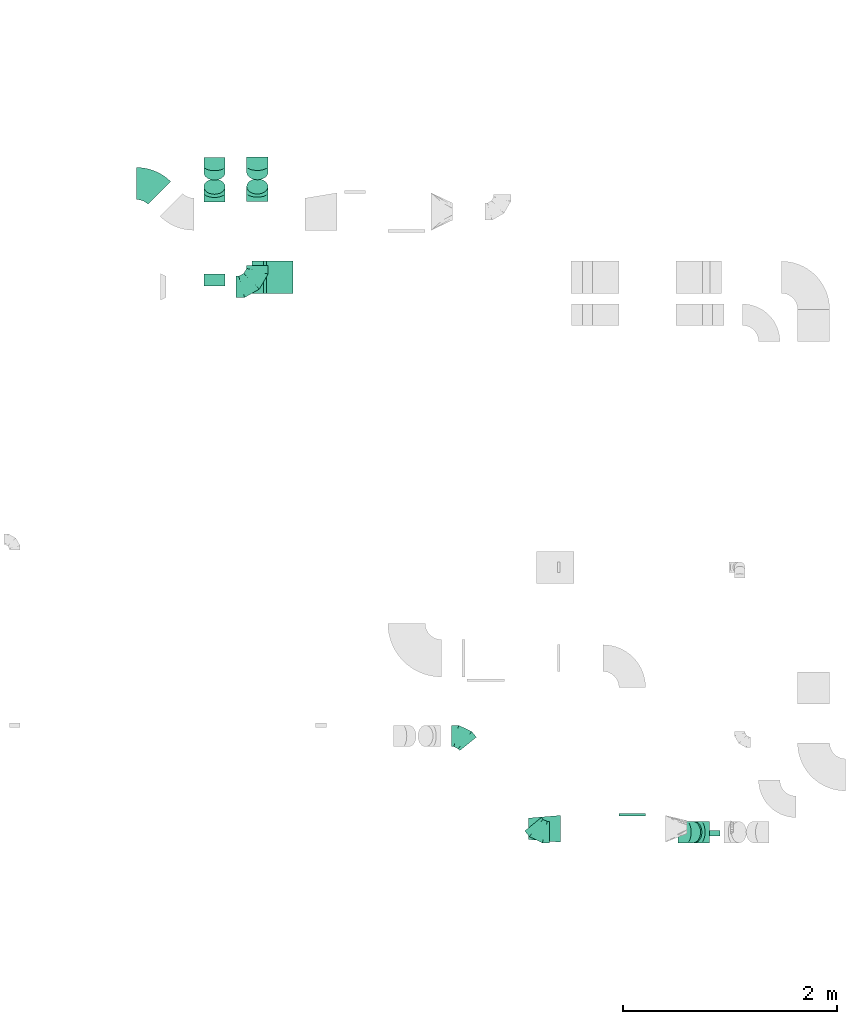
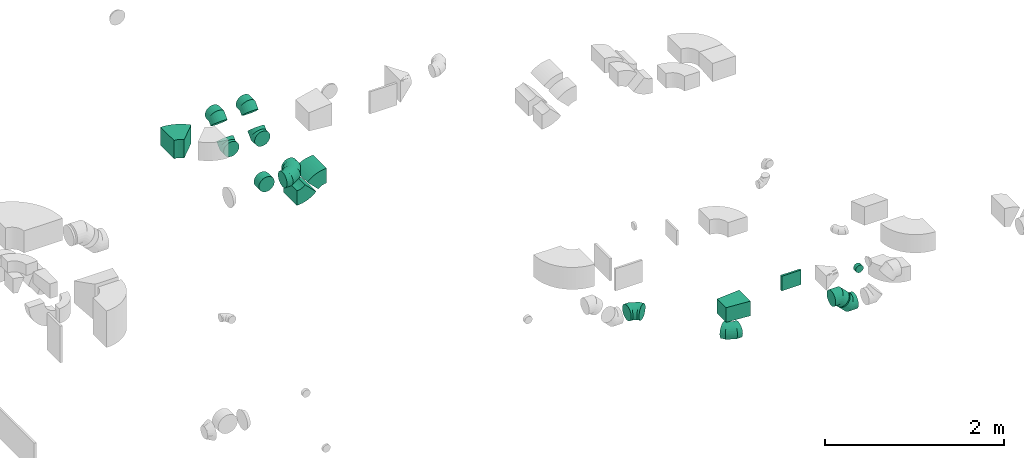
# One storey, part 28 of 44: 16 flow fittings.
"""IFC2X3 building model written with IfcOpenShell, lengths in millimetres."""

from ifc_helpers import new_model, entity, si_unit, converted_unit, derived_unit, direction, frame, frame_2d, origin, origin_2d_with_axis, place, context, subcontext, project, spatial, polyline, circle_curve, parameter, trimmed, segment, composite_curve, rectangle, outline, extrude, faceted_brep, source, transform, mapped, material, type_object, type_shapes, element, save


model = new_model("IFC2X3")

# Units and contexts
model_context = context("Model", 3, precision=0.01, world=origin(), true_north=direction((6.12303176911189e-17, 1.0)))
body_context = subcontext(model_context, "Body", "Model", "MODEL_VIEW")
ifc_project = project(units=[si_unit("LENGTHUNIT", "METRE", prefix="MILLI"), si_unit("AREAUNIT", "SQUARE_METRE"), si_unit("VOLUMEUNIT", "CUBIC_METRE"), converted_unit("PLANEANGLEUNIT", "DEGREE", entity("IfcRatioMeasure", 0.0174532925199433), si_unit("PLANEANGLEUNIT", "RADIAN"), dimensions=[0, 0, 0, 0, 0, 0, 0]), si_unit("MASSUNIT", "GRAM", prefix="KILO"), derived_unit("MASSDENSITYUNIT", [(si_unit("MASSUNIT", "GRAM", prefix="KILO"), 1), (si_unit("LENGTHUNIT", "METRE"), -3)]), derived_unit("MOMENTOFINERTIAUNIT", [(si_unit("LENGTHUNIT", "METRE"), 4)]), si_unit("TIMEUNIT", "SECOND"), si_unit("FREQUENCYUNIT", "HERTZ"), si_unit("THERMODYNAMICTEMPERATUREUNIT", "DEGREE_CELSIUS"), derived_unit("THERMALTRANSMITTANCEUNIT", [(si_unit("MASSUNIT", "GRAM", prefix="KILO"), 1), (si_unit("THERMODYNAMICTEMPERATUREUNIT", "KELVIN"), -1), (si_unit("TIMEUNIT", "SECOND"), -3)]), derived_unit("VOLUMETRICFLOWRATEUNIT", [(si_unit("LENGTHUNIT", "METRE"), 3), (si_unit("TIMEUNIT", "SECOND"), -1)]), derived_unit("MASSFLOWRATEUNIT", [(si_unit("MASSUNIT", "GRAM", prefix="KILO"), 1), (si_unit("TIMEUNIT", "SECOND"), -1)]), derived_unit("ROTATIONALFREQUENCYUNIT", [(si_unit("TIMEUNIT", "SECOND"), -1)]), si_unit("ELECTRICCURRENTUNIT", "AMPERE"), si_unit("ELECTRICVOLTAGEUNIT", "VOLT"), si_unit("POWERUNIT", "WATT"), si_unit("FORCEUNIT", "NEWTON", prefix="KILO"), si_unit("ILLUMINANCEUNIT", "LUX"), si_unit("LUMINOUSFLUXUNIT", "LUMEN"), si_unit("LUMINOUSINTENSITYUNIT", "CANDELA"), derived_unit("USERDEFINED", [(si_unit("MASSUNIT", "GRAM", prefix="KILO"), -1), (si_unit("LENGTHUNIT", "METRE"), -2), (si_unit("TIMEUNIT", "SECOND"), 3), (si_unit("LUMINOUSFLUXUNIT", "LUMEN"), 1)]), derived_unit("LINEARVELOCITYUNIT", [(si_unit("LENGTHUNIT", "METRE"), 1), (si_unit("TIMEUNIT", "SECOND"), -1)]), si_unit("PRESSUREUNIT", "PASCAL"), derived_unit("USERDEFINED", [(si_unit("LENGTHUNIT", "METRE"), -2), (si_unit("MASSUNIT", "GRAM", prefix="KILO"), 1), (si_unit("TIMEUNIT", "SECOND"), -2)]), derived_unit("LINEARFORCEUNIT", [(si_unit("MASSUNIT", "GRAM", prefix="KILO"), 1), (si_unit("LENGTHUNIT", "METRE"), 1), (si_unit("TIMEUNIT", "SECOND"), -2), (si_unit("LENGTHUNIT", "METRE"), -1)]), derived_unit("PLANARFORCEUNIT", [(si_unit("MASSUNIT", "GRAM", prefix="KILO"), 1), (si_unit("LENGTHUNIT", "METRE"), 1), (si_unit("TIMEUNIT", "SECOND"), -2), (si_unit("LENGTHUNIT", "METRE"), -2)])], contexts=[model_context])

# Site, building, storey
site_placement = place(None, origin())
site = spatial("IfcSite", under=ifc_project, at=site_placement, CompositionType="ELEMENT")
building_placement = place(site_placement, origin())
building = spatial("IfcBuilding", under=site, at=building_placement, CompositionType="ELEMENT")
storey_placement = place(building_placement, frame((0.0, 0.0, 15900.0)))
storey = spatial("IfcBuildingStorey", under=building, at=storey_placement, CompositionType="ELEMENT", Elevation=15900.0)

# Flow fittings
ifc_material = material()
duct_fitting_type_1 = type_object("IfcDuctFittingType", PredefinedType="NOTDEFINED", material=ifc_material)
shared_shape_1 = source(origin(), body_context, "Body", "SweptSolid", [
    extrude(rectangle(XDim=250.0, YDim=26.0960000000122, at=origin_2d_with_axis()), frame((6.95, 0.0, -100.0), z_axis=(0.0, 0.0, 1.0), x_axis=(0.0, -1.0, 0.0)), (0.0, 0.0, 1.0), 200.0),
])
type_shapes(duct_fitting_type_1, [shared_shape_1])
flow_fitting_1_placement = place(storey_placement, frame((60349.84, 9495.12, 3375.0), z_axis=(0.0, 0.0, -1.0), x_axis=(0.0, 1.0, 0.0)))
element("IfcFlowFitting", 1, at=flow_fitting_1_placement, inside=storey, type_object=duct_fitting_type_1, material=ifc_material, context=body_context, shape_type="MappedRepresentation", body=[
    mapped(shared_shape_1, transform((0.0, 0.0, 0.0), scale=1.0)),
])
duct_fitting_type_2 = type_object("IfcDuctFittingType", PredefinedType="NOTDEFINED", material=ifc_material)
shared_shape_2 = source(origin(), body_context, "Body", "SweptSolid", [
    extrude(outline(polyline([(-141.18, -112.11), (159.86, -112.11), (139.1, 137.03), (-157.79, 87.2), (-141.18, -112.11)])), frame((150.0, 0.0, -100.0), z_axis=(0.0, 0.0, 1.0), x_axis=(0.996545758244879, -0.0830454798537418, 0.0)), (0.0, 0.0, 1.0), 200.0),
])
type_shapes(duct_fitting_type_2, [shared_shape_2])
flow_fitting_2_placement = place(storey_placement, frame((59379.84, 9370.12, 3375.0)))
element("IfcFlowFitting", 2, at=flow_fitting_2_placement, inside=storey, type_object=duct_fitting_type_2, material=ifc_material, context=body_context, shape_type="MappedRepresentation", body=[
    mapped(shared_shape_2, transform((0.0, 0.0, 0.0), scale=1.0)),
])
duct_fitting_type_3 = type_object("IfcDuctFittingType", PredefinedType="NOTDEFINED", material=ifc_material)
shared_shape_3 = source(origin(), body_context, "Body", "Brep", [
    faceted_brep([(-200.0, 0.0, -100.0), (-200.0, -25.88, -96.59), (-200.0, -50.0, -86.6), (-200.0, -70.71, -70.71), (-200.0, -86.6, -50.0), (-200.0, -96.59, -25.88), (-200.0, -100.0, 0.0), (-200.0, -96.59, 25.88), (-200.0, -86.6, 50.0), (-200.0, -70.71, 70.71), (-200.0, -50.0, 86.6), (-200.0, -25.88, 96.59), (-200.0, 0.0, 100.0), (-200.0, 25.88, 96.59), (-200.0, 50.0, 86.6), (-200.0, 70.71, 70.71), (-200.0, 86.6, 50.0), (-200.0, 96.59, 25.88), (-200.0, 100.0, 0.0), (-200.0, 96.59, -25.88), (-200.0, 86.6, -50.0), (-200.0, 70.71, -70.71), (-200.0, 50.0, -86.6), (-200.0, 25.88, -96.59), (-153.35, 25.88, 96.59), (-159.81, 50.0, 86.6), (-146.41, 0.0, 100.0), (-165.36, 70.71, 70.71), (-172.29, 96.59, 25.88), (-173.21, 100.0, 0.0), (-169.62, 86.6, 50.0), (-169.62, 86.6, -50.0), (-165.36, 70.71, -70.71), (-172.29, 96.59, -25.88), (-153.35, 25.88, -96.59), (-146.41, 0.0, -100.0), (-159.81, 50.0, -86.6), (-139.48, -25.88, -96.59), (-133.01, -50.0, -86.6), (-127.46, -70.71, -70.71), (-123.21, -86.6, -50.0), (-120.53, -96.59, -25.88), (-119.62, -100.0, 0.0), (-120.53, -96.59, 25.88), (-123.21, -86.6, 50.0), (-127.46, -70.71, 70.71), (-133.01, -50.0, 86.6), (-139.48, -25.88, 96.59), (-72.54, 72.54, 96.59), (-90.19, 90.19, 86.6), (-53.59, 53.59, 100.0), (-105.35, 105.35, 70.71), (-116.99, 116.99, 50.0), (-124.3, 124.3, 25.88), (-126.79, 126.79, 0.0), (-124.3, 124.3, -25.88), (-116.99, 116.99, -50.0), (-105.35, 105.35, -70.71), (-72.54, 72.54, -96.59), (-53.59, 53.59, -100.0), (-90.19, 90.19, -86.6), (-34.64, 34.64, -96.59), (-16.99, 16.99, -86.6), (-1.83, 1.83, -70.71), (9.81, -9.81, -50.0), (17.12, -17.12, -25.88), (19.62, -19.62, 0.0), (17.12, -17.12, 25.88), (9.81, -9.81, 50.0), (-1.83, 1.83, 70.71), (-16.99, 16.99, 86.6), (-34.64, 34.64, 96.59), (-25.88, 153.35, 96.59), (-50.0, 159.81, 86.6), (0.0, 146.41, 100.0), (-70.71, 165.36, 70.71), (-86.6, 169.62, 50.0), (-96.59, 172.29, 25.88), (-100.0, 173.21, 0.0), (-96.59, 172.29, -25.88), (-86.6, 169.62, -50.0), (-70.71, 165.36, -70.71), (-25.88, 153.35, -96.59), (0.0, 146.41, -100.0), (-50.0, 159.81, -86.6), (25.88, 139.48, -96.59), (50.0, 133.01, -86.6), (70.71, 127.46, -70.71), (86.6, 123.21, -50.0), (96.59, 120.53, -25.88), (100.0, 119.62, 0.0), (96.59, 120.53, 25.88), (86.6, 123.21, 50.0), (70.71, 127.46, 70.71), (50.0, 133.01, 86.6), (25.88, 139.48, 96.59), (-25.88, 200.0, -96.59), (-50.0, 200.0, -86.6), (-70.71, 200.0, -70.71), (-86.6, 200.0, -50.0), (-96.59, 200.0, -25.88), (-100.0, 200.0, 0.0), (-96.59, 200.0, 25.88), (-86.6, 200.0, 50.0), (-70.71, 200.0, 70.71), (-50.0, 200.0, 86.6), (-25.88, 200.0, 96.59), (0.0, 200.0, 100.0), (25.88, 200.0, 96.59), (50.0, 200.0, 86.6), (70.71, 200.0, 70.71), (86.6, 200.0, 50.0), (96.59, 200.0, 25.88), (100.0, 200.0, 0.0), (96.59, 200.0, -25.88), (86.6, 200.0, -50.0), (70.71, 200.0, -70.71), (50.0, 200.0, -86.6), (25.88, 200.0, -96.59), (0.0, 200.0, -100.0)], [[[0, 1, 2, 3, 4, 5, 6, 7, 8, 9, 10, 11, 12, 13, 14, 15, 16, 17, 18, 19, 20, 21, 22, 23]], [[24, 25, 14, 13]], [[26, 24, 13, 12]], [[14, 25, 27, 15]], [[28, 29, 18, 17]], [[30, 28, 17, 16]], [[15, 27, 30, 16]], [[20, 31, 32, 21]], [[33, 31, 20, 19]], [[18, 29, 33, 19]], [[34, 35, 0, 23]], [[36, 34, 23, 22]], [[32, 36, 22, 21]], [[1, 0, 35, 37]], [[2, 1, 37, 38]], [[38, 39, 3, 2]], [[5, 4, 40, 41]], [[6, 5, 41, 42]], [[39, 40, 4, 3]], [[6, 42, 43, 7]], [[7, 43, 44, 8]], [[8, 44, 45, 9]], [[9, 45, 46, 10]], [[10, 46, 47, 11]], [[26, 12, 11, 47]], [[48, 49, 25, 24]], [[50, 48, 24, 26]], [[27, 25, 49, 51]], [[52, 53, 28, 30]], [[51, 52, 30, 27]], [[29, 28, 53, 54]], [[55, 56, 31, 33]], [[54, 55, 33, 29]], [[32, 31, 56, 57]], [[58, 59, 35, 34]], [[60, 58, 34, 36]], [[57, 60, 36, 32]], [[37, 35, 59, 61]], [[38, 37, 61, 62]], [[39, 38, 62, 63]], [[41, 40, 64, 65]], [[42, 41, 65, 66]], [[63, 64, 40, 39]], [[43, 42, 66, 67]], [[44, 43, 67, 68]], [[68, 69, 45, 44]], [[46, 45, 69, 70]], [[47, 46, 70, 71]], [[26, 47, 71, 50]], [[72, 73, 49, 48]], [[74, 72, 48, 50]], [[51, 49, 73, 75]], [[76, 77, 53, 52]], [[75, 76, 52, 51]], [[54, 53, 77, 78]], [[79, 80, 56, 55]], [[78, 79, 55, 54]], [[57, 56, 80, 81]], [[82, 83, 59, 58]], [[84, 82, 58, 60]], [[81, 84, 60, 57]], [[61, 59, 83, 85]], [[62, 61, 85, 86]], [[63, 62, 86, 87]], [[65, 64, 88, 89]], [[66, 65, 89, 90]], [[87, 88, 64, 63]], [[67, 66, 90, 91]], [[68, 67, 91, 92]], [[92, 93, 69, 68]], [[70, 69, 93, 94]], [[71, 70, 94, 95]], [[50, 71, 95, 74]], [[96, 97, 98, 99, 100, 101, 102, 103, 104, 105, 106, 107, 108, 109, 110, 111, 112, 113, 114, 115, 116, 117, 118, 119]], [[72, 74, 107, 106]], [[73, 72, 106, 105]], [[75, 73, 105, 104]], [[102, 101, 78, 77]], [[103, 102, 77, 76]], [[75, 104, 103, 76]], [[78, 101, 100, 79]], [[79, 100, 99, 80]], [[80, 99, 98, 81]], [[84, 97, 96, 82]], [[82, 96, 119, 83]], [[84, 81, 98, 97]], [[118, 117, 86, 85]], [[119, 118, 85, 83]], [[116, 87, 86, 117]], [[88, 115, 114, 89]], [[89, 114, 113, 90]], [[115, 88, 87, 116]], [[91, 90, 113, 112]], [[92, 91, 112, 111]], [[111, 110, 93, 92]], [[95, 94, 109, 108]], [[74, 95, 108, 107]], [[110, 109, 94, 93]]]),
])
type_shapes(duct_fitting_type_3, [shared_shape_3])
flow_fitting_3_placement = place(storey_placement, frame((56845.04, 14435.52, 3050.0)))
element("IfcFlowFitting", 3, at=flow_fitting_3_placement, inside=storey, type_object=duct_fitting_type_3, material=ifc_material, context=body_context, shape_type="MappedRepresentation", body=[
    mapped(shared_shape_3, transform((0.0, 0.0, 0.0), scale=1.0)),
])
duct_fitting_type_4 = type_object("IfcDuctFittingType", PredefinedType="NOTDEFINED", material=ifc_material)
shared_shape_4 = source(origin(), body_context, "Body", "Brep", [
    faceted_brep([(-82.84, 0.0, -100.0), (-82.84, -25.88, -96.59), (-82.84, -50.0, -86.6), (-82.84, -70.71, -70.71), (-82.84, -86.6, -50.0), (-82.84, -96.59, -25.88), (-82.84, -100.0, 0.0), (-82.84, -96.59, 25.88), (-82.84, -86.6, 50.0), (-82.84, -70.71, 70.71), (-82.84, -50.0, 86.6), (-82.84, -25.88, 96.59), (-82.84, 0.0, 100.0), (-82.84, 25.88, 96.59), (-82.84, 50.0, 86.6), (-82.84, 70.71, 70.71), (-82.84, 86.6, 50.0), (-82.84, 96.59, 25.88), (-82.84, 100.0, 0.0), (-82.84, 96.59, -25.88), (-82.84, 86.6, -50.0), (-82.84, 70.71, -70.71), (-82.84, 50.0, -86.6), (-82.84, 25.88, -96.59), (-10.72, 25.88, 96.59), (-20.71, 50.0, 86.6), (0.0, 0.0, 100.0), (-29.29, 70.71, 70.71), (-35.87, 86.6, 50.0), (-40.01, 96.59, 25.88), (-41.42, 100.0, 0.0), (-40.01, 96.59, -25.88), (-35.87, 86.6, -50.0), (-29.29, 70.71, -70.71), (-10.72, 25.88, -96.59), (0.0, 0.0, -100.0), (-20.71, 50.0, -86.6), (10.72, -25.88, -96.59), (20.71, -50.0, -86.6), (29.29, -70.71, -70.71), (35.87, -86.6, -50.0), (40.01, -96.59, -25.88), (41.42, -100.0, 0.0), (40.01, -96.59, 25.88), (35.87, -86.6, 50.0), (29.29, -70.71, 70.71), (20.71, -50.0, 86.6), (10.72, -25.88, 96.59), (58.58, 58.58, 100.0), (40.28, 76.88, 96.59), (23.22, 93.93, 86.6), (8.58, 108.58, 70.71), (-2.66, 119.82, 50.0), (-9.72, 126.88, 25.88), (-12.13, 129.29, 0.0), (-9.72, 126.88, -25.88), (-2.66, 119.82, -50.0), (8.58, 108.58, -70.71), (23.22, 93.93, -86.6), (40.28, 76.88, -96.59), (58.58, 58.58, -100.0), (76.88, 40.28, -96.59), (93.93, 23.22, -86.6), (108.58, 8.58, -70.71), (119.82, -2.66, -50.0), (126.88, -9.72, -25.88), (129.29, -12.13, 0.0), (126.88, -9.72, 25.88), (119.82, -2.66, 50.0), (108.58, 8.58, 70.71), (93.93, 23.22, 86.6), (76.88, 40.28, 96.59)], [[[0, 1, 2, 3, 4, 5, 6, 7, 8, 9, 10, 11, 12, 13, 14, 15, 16, 17, 18, 19, 20, 21, 22, 23]], [[24, 25, 14, 13]], [[26, 24, 13, 12]], [[14, 25, 27, 15]], [[28, 29, 17, 16]], [[28, 16, 15, 27]], [[30, 18, 17, 29]], [[31, 32, 20, 19]], [[30, 31, 19, 18]], [[32, 33, 21, 20]], [[34, 35, 0, 23]], [[36, 34, 23, 22]], [[33, 36, 22, 21]], [[1, 0, 35, 37]], [[2, 1, 37, 38]], [[38, 39, 3, 2]], [[5, 4, 40, 41]], [[6, 5, 41, 42]], [[39, 40, 4, 3]], [[6, 42, 43, 7]], [[7, 43, 44, 8]], [[8, 44, 45, 9]], [[9, 45, 46, 10]], [[10, 46, 47, 11]], [[26, 12, 11, 47]], [[24, 26, 48, 49]], [[25, 24, 49, 50]], [[27, 25, 50, 51]], [[29, 28, 52, 53]], [[30, 29, 53, 54]], [[51, 52, 28, 27]], [[30, 54, 55, 31]], [[31, 55, 56, 32]], [[57, 33, 32, 56]], [[36, 58, 59, 34]], [[34, 59, 60, 35]], [[58, 36, 33, 57]], [[35, 60, 61, 37]], [[37, 61, 62, 38]], [[63, 39, 38, 62]], [[40, 64, 65, 41]], [[41, 65, 66, 42]], [[64, 40, 39, 63]], [[43, 42, 66, 67]], [[44, 43, 67, 68]], [[68, 69, 45, 44]], [[47, 46, 70, 71]], [[26, 47, 71, 48]], [[69, 70, 46, 45]], [[59, 58, 57, 56, 55, 54, 53, 52, 51, 50, 49, 48, 71, 70, 69, 68, 67, 66, 65, 64, 63, 62, 61, 60]]]),
])
type_shapes(duct_fitting_type_4, [shared_shape_4])
for number, where, z_axis, x_axis in (
    (4, (56444.3, 15563.36, 3300.0), (1.0, 0.0, 0.0), (0.0, -1.0, 0.0)),
    (5, (56444.3, 15313.36, 3050.0), (-1.0, 0.0, 0.0), (0.0, -0.707106781186484, -0.707106781186611)),
    (6, (56845.04, 15565.52, 3300.0), (1.0, 0.0, 0.0), (0.0, -1.0, 0.0)),
    (7, (56845.04, 15315.52, 3050.0), (-1.0, 0.0, 0.0), (0.0, -0.707106781186484, -0.707106781186611)),
    (8, (60988.67, 9338.57, 2945.0), (0.0, 1.0, 0.0), (-1.0, 0.0, 0.0)),
    (9, (60858.85, 9338.57, 3074.82), (0.0, -1.0, 0.0), (-0.707106781186468, 0.0, 0.707106781186627)),
):
    element("IfcFlowFitting", number, at=place(storey_placement, frame(where, z_axis=z_axis, x_axis=x_axis)), inside=storey, type_object=duct_fitting_type_4, material=ifc_material, context=body_context, shape_type="MappedRepresentation", body=[
        mapped(shared_shape_4, transform((0.0, 0.0, 0.0), scale=1.0)),
    ])
duct_fitting_type_5 = type_object("IfcDuctFittingType", PredefinedType="NOTDEFINED", material=ifc_material)
shared_shape_5 = source(origin(), body_context, "Body", "Brep", [
    faceted_brep([(20.0, 12.94, -48.3), (20.0, 25.0, -43.3), (20.0, 35.36, -35.36), (20.0, 43.3, -25.0), (20.0, 48.3, -12.94), (20.0, 50.0, 0.0), (20.0, 48.3, 12.94), (20.0, 43.3, 25.0), (20.0, 35.36, 35.36), (20.0, 25.0, 43.3), (20.0, 12.94, 48.3), (20.0, 0.0, 50.0), (20.0, -12.94, 48.3), (20.0, -25.0, 43.3), (20.0, -35.36, 35.36), (20.0, -43.3, 25.0), (20.0, -48.3, 12.94), (20.0, -50.0, 0.0), (20.0, -48.3, -12.94), (20.0, -43.3, -25.0), (20.0, -35.36, -35.36), (20.0, -25.0, -43.3), (20.0, -12.94, -48.3), (20.0, 0.0, -50.0), (0.0, 0.0, 50.0), (0.0, 12.94, 48.3), (-31.1, 12.94, 48.3), (-31.1, 0.0, 50.0), (0.0, 25.0, 43.3), (-31.1, 25.0, 43.3), (0.0, 35.36, 35.36), (-31.1, 35.36, 35.36), (0.0, 43.3, 25.0), (0.0, 48.3, 12.94), (-31.1, 48.3, 12.94), (-31.1, 43.3, 25.0), (0.0, 50.0, 0.0), (-31.1, 50.0, 0.0), (0.0, 48.3, -12.94), (-31.1, 48.3, -12.94), (0.0, 43.3, -25.0), (-31.1, 43.3, -25.0), (0.0, 35.36, -35.36), (-31.1, 35.36, -35.36), (0.0, 25.0, -43.3), (0.0, 12.94, -48.3), (-31.1, 12.94, -48.3), (-31.1, 25.0, -43.3), (0.0, 0.0, -50.0), (-31.1, 0.0, -50.0), (0.0, -12.94, -48.3), (-31.1, -12.94, -48.3), (0.0, -25.0, -43.3), (-31.1, -25.0, -43.3), (0.0, -35.36, -35.36), (-31.1, -35.36, -35.36), (0.0, -43.3, -25.0), (0.0, -48.3, -12.94), (-31.1, -48.3, -12.94), (-31.1, -43.3, -25.0), (0.0, -50.0, 0.0), (-31.1, -50.0, 0.0), (0.0, -48.3, 12.94), (-31.1, -48.3, 12.94), (0.0, -43.3, 25.0), (-31.1, -43.3, 25.0), (0.0, -35.36, 35.36), (-31.1, -35.36, 35.36), (0.0, -25.0, 43.3), (0.0, -12.94, 48.3), (-31.1, -12.94, 48.3), (-31.1, -25.0, 43.3)], [[[0, 1, 2, 3, 4, 5, 6, 7, 8, 9, 10, 11, 12, 13, 14, 15, 16, 17, 18, 19, 20, 21, 22, 23]], [[24, 11, 10, 25, 26, 27]], [[25, 10, 9, 28, 29, 26]], [[28, 9, 8, 30, 31, 29]], [[32, 7, 6, 33, 34, 35]], [[33, 6, 5, 36, 37, 34]], [[30, 8, 7, 32, 35, 31]], [[36, 5, 4, 38, 39, 37]], [[38, 4, 3, 40, 41, 39]], [[40, 3, 2, 42, 43, 41]], [[44, 1, 0, 45, 46, 47]], [[45, 0, 23, 48, 49, 46]], [[42, 2, 1, 44, 47, 43]], [[48, 23, 22, 50, 51, 49]], [[50, 22, 21, 52, 53, 51]], [[52, 21, 20, 54, 55, 53]], [[56, 19, 18, 57, 58, 59]], [[57, 18, 17, 60, 61, 58]], [[54, 20, 19, 56, 59, 55]], [[60, 17, 16, 62, 63, 61]], [[62, 16, 15, 64, 65, 63]], [[64, 15, 14, 66, 67, 65]], [[68, 13, 12, 69, 70, 71]], [[69, 12, 11, 24, 27, 70]], [[66, 14, 13, 68, 71, 67]], [[49, 51, 53, 55, 59, 58, 61, 63, 65, 67, 71, 70, 27, 26, 29, 31, 35, 34, 37, 39, 41, 43, 47, 46]]]),
])
type_shapes(duct_fitting_type_5, [shared_shape_5])
flow_fitting_4_placement = place(storey_placement, frame((61120.03, 9322.62, 3375.0), z_axis=(0.0, 0.0, -1.0), x_axis=(0.0, -1.0, 0.0)))
element("IfcFlowFitting", 10, at=flow_fitting_4_placement, inside=storey, type_object=duct_fitting_type_5, material=ifc_material, context=body_context, shape_type="MappedRepresentation", body=[
    mapped(shared_shape_5, transform((0.0, 0.0, 0.0), scale=1.0)),
])
duct_fitting_type_6 = type_object("IfcDuctFittingType", PredefinedType="NOTDEFINED", material=ifc_material)
shared_shape_6 = source(origin(), body_context, "Body", "Brep", [
    faceted_brep([(20.0, 25.88, -96.59), (20.0, 50.0, -86.6), (20.0, 70.71, -70.71), (20.0, 86.6, -50.0), (20.0, 96.59, -25.88), (20.0, 100.0, 0.0), (20.0, 96.59, 25.88), (20.0, 86.6, 50.0), (20.0, 70.71, 70.71), (20.0, 50.0, 86.6), (20.0, 25.88, 96.59), (20.0, 0.0, 100.0), (20.0, -25.88, 96.59), (20.0, -50.0, 86.6), (20.0, -70.71, 70.71), (20.0, -86.6, 50.0), (20.0, -96.59, 25.88), (20.0, -100.0, 0.0), (20.0, -96.59, -25.88), (20.0, -86.6, -50.0), (20.0, -70.71, -70.71), (20.0, -50.0, -86.6), (20.0, -25.88, -96.59), (20.0, 0.0, -100.0), (0.0, 0.0, 100.0), (0.0, 25.88, 96.59), (-93.9, 25.88, 96.59), (-93.9, 0.0, 100.0), (0.0, 50.0, 86.6), (-93.9, 50.0, 86.6), (0.0, 70.71, 70.71), (-93.9, 70.71, 70.71), (0.0, 86.6, 50.0), (0.0, 96.59, 25.88), (-93.9, 96.59, 25.88), (-93.9, 86.6, 50.0), (0.0, 100.0, 0.0), (-93.9, 100.0, 0.0), (0.0, 96.59, -25.88), (-93.9, 96.59, -25.88), (0.0, 86.6, -50.0), (-93.9, 86.6, -50.0), (0.0, 70.71, -70.71), (-93.9, 70.71, -70.71), (0.0, 50.0, -86.6), (0.0, 25.88, -96.59), (-93.9, 25.88, -96.59), (-93.9, 50.0, -86.6), (0.0, 0.0, -100.0), (-93.9, 0.0, -100.0), (0.0, -25.88, -96.59), (-93.9, -25.88, -96.59), (0.0, -50.0, -86.6), (-93.9, -50.0, -86.6), (0.0, -70.71, -70.71), (-93.9, -70.71, -70.71), (0.0, -86.6, -50.0), (0.0, -96.59, -25.88), (-93.9, -96.59, -25.88), (-93.9, -86.6, -50.0), (0.0, -100.0, 0.0), (-93.9, -100.0, 0.0), (0.0, -96.59, 25.88), (-93.9, -96.59, 25.88), (0.0, -86.6, 50.0), (-93.9, -86.6, 50.0), (0.0, -70.71, 70.71), (-93.9, -70.71, 70.71), (0.0, -50.0, 86.6), (0.0, -25.88, 96.59), (-93.9, -25.88, 96.59), (-93.9, -50.0, 86.6)], [[[0, 1, 2, 3, 4, 5, 6, 7, 8, 9, 10, 11, 12, 13, 14, 15, 16, 17, 18, 19, 20, 21, 22, 23]], [[24, 11, 10, 25, 26, 27]], [[25, 10, 9, 28, 29, 26]], [[28, 9, 8, 30, 31, 29]], [[32, 7, 6, 33, 34, 35]], [[33, 6, 5, 36, 37, 34]], [[30, 8, 7, 32, 35, 31]], [[36, 5, 4, 38, 39, 37]], [[38, 4, 3, 40, 41, 39]], [[40, 3, 2, 42, 43, 41]], [[44, 1, 0, 45, 46, 47]], [[45, 0, 23, 48, 49, 46]], [[42, 2, 1, 44, 47, 43]], [[48, 23, 22, 50, 51, 49]], [[50, 22, 21, 52, 53, 51]], [[52, 21, 20, 54, 55, 53]], [[56, 19, 18, 57, 58, 59]], [[57, 18, 17, 60, 61, 58]], [[54, 20, 19, 56, 59, 55]], [[60, 17, 16, 62, 63, 61]], [[62, 16, 15, 64, 65, 63]], [[64, 15, 14, 66, 67, 65]], [[68, 13, 12, 69, 70, 71]], [[69, 12, 11, 24, 27, 70]], [[66, 14, 13, 68, 71, 67]], [[49, 51, 53, 55, 59, 58, 61, 63, 65, 67, 71, 70, 27, 26, 29, 31, 35, 34, 37, 39, 41, 43, 47, 46]]]),
])
type_shapes(duct_fitting_type_6, [shared_shape_6])
flow_fitting_5_placement = place(storey_placement, frame((56444.3, 14535.52, 3050.0), z_axis=(0.0, 0.0, -1.0), x_axis=(0.0, 1.0, 0.0)))
element("IfcFlowFitting", 11, at=flow_fitting_5_placement, inside=storey, type_object=duct_fitting_type_6, material=ifc_material, context=body_context, shape_type="MappedRepresentation", body=[
    mapped(shared_shape_6, transform((0.0, 0.0, 0.0), scale=1.0)),
])
duct_fitting_type_7 = type_object("IfcDuctFittingType", PredefinedType="NOTDEFINED", material=ifc_material)
shared_shape_7 = source(origin(), body_context, "Body", "Brep", [
    faceted_brep([(-95.4, 0.0, -100.0), (-95.4, -25.88, -96.59), (-95.4, -50.0, -86.6), (-95.4, -70.71, -70.71), (-95.4, -86.6, -50.0), (-95.4, -96.59, -25.88), (-95.4, -100.0, 0.0), (-95.4, -96.59, 25.88), (-95.4, -86.6, 50.0), (-95.4, -70.71, 70.71), (-95.4, -50.0, 86.6), (-95.4, -25.88, 96.59), (-95.4, 0.0, 100.0), (-95.4, 25.88, 96.59), (-95.4, 50.0, 86.6), (-95.4, 70.71, 70.71), (-95.4, 86.6, 50.0), (-95.4, 96.59, 25.88), (-95.4, 100.0, 0.0), (-95.4, 96.59, -25.88), (-95.4, 86.6, -50.0), (-95.4, 70.71, -70.71), (-95.4, 50.0, -86.6), (-95.4, 25.88, -96.59), (-56.0, 25.88, 96.59), (-61.45, 50.0, 86.6), (-50.14, 0.0, 100.0), (-66.14, 70.71, 70.71), (-72.0, 96.59, 25.88), (-72.77, 100.0, 0.0), (-69.74, 86.6, 50.0), (-69.74, 86.6, -50.0), (-66.14, 70.71, -70.71), (-72.0, 96.59, -25.88), (-56.0, 25.88, -96.59), (-50.14, 0.0, -100.0), (-61.45, 50.0, -86.6), (-44.28, -25.88, -96.59), (-38.83, -50.0, -86.6), (-34.14, -70.71, -70.71), (-30.54, -86.6, -50.0), (-28.28, -96.59, -25.88), (-27.51, -100.0, 0.0), (-28.28, -96.59, 25.88), (-30.54, -86.6, 50.0), (-34.14, -70.71, 70.71), (-38.83, -50.0, 86.6), (-44.28, -25.88, 96.59), (15.13, 59.81, 96.59), (-0.18, 79.22, 86.6), (31.55, 38.97, 100.0), (-13.33, 95.9, 70.71), (-23.42, 108.7, 50.0), (-29.76, 116.74, 25.88), (-31.92, 119.48, 0.0), (-29.76, 116.74, -25.88), (-23.42, 108.7, -50.0), (-13.33, 95.9, -70.71), (15.13, 59.81, -96.59), (31.55, 38.97, -100.0), (-0.18, 79.22, -86.6), (47.98, 18.13, -96.59), (63.29, -1.29, -86.6), (76.44, -17.97, -70.71), (86.52, -30.76, -50.0), (92.87, -38.81, -25.88), (95.03, -41.55, 0.0), (92.87, -38.81, 25.88), (86.52, -30.76, 50.0), (76.44, -17.97, 70.71), (63.29, -1.29, 86.6), (47.98, 18.13, 96.59), (60.03, 74.14, 100.0), (39.92, 90.42, 96.59), (21.18, 105.6, 86.6), (5.08, 118.64, 70.71), (-7.27, 128.64, 50.0), (-15.03, 134.92, 25.88), (-17.68, 137.07, 0.0), (-15.03, 134.92, -25.88), (-7.27, 128.64, -50.0), (5.08, 118.64, -70.71), (21.18, 105.6, -86.6), (39.92, 90.42, -96.59), (60.03, 74.14, -100.0), (80.15, 57.85, -96.59), (98.89, 42.67, -86.6), (114.99, 29.64, -70.71), (127.34, 19.64, -50.0), (135.1, 13.35, -25.88), (137.75, 11.2, 0.0), (135.1, 13.35, 25.88), (127.34, 19.64, 50.0), (114.99, 29.64, 70.71), (98.89, 42.67, 86.6), (80.15, 57.85, 96.59)], [[[0, 1, 2, 3, 4, 5, 6, 7, 8, 9, 10, 11, 12, 13, 14, 15, 16, 17, 18, 19, 20, 21, 22, 23]], [[24, 25, 14, 13]], [[26, 24, 13, 12]], [[14, 25, 27, 15]], [[28, 29, 18, 17]], [[30, 28, 17, 16]], [[15, 27, 30, 16]], [[20, 31, 32, 21]], [[33, 31, 20, 19]], [[18, 29, 33, 19]], [[34, 35, 0, 23]], [[36, 34, 23, 22]], [[32, 36, 22, 21]], [[1, 0, 35, 37]], [[2, 1, 37, 38]], [[3, 2, 38, 39]], [[5, 4, 40, 41]], [[6, 5, 41, 42]], [[39, 40, 4, 3]], [[6, 42, 43, 7]], [[7, 43, 44, 8]], [[45, 9, 8, 44]], [[9, 45, 46, 10]], [[10, 46, 47, 11]], [[26, 12, 11, 47]], [[48, 49, 25, 24]], [[50, 48, 24, 26]], [[27, 25, 49, 51]], [[52, 53, 28, 30]], [[51, 52, 30, 27]], [[29, 28, 53, 54]], [[55, 56, 31, 33]], [[54, 55, 33, 29]], [[32, 31, 56, 57]], [[58, 59, 35, 34]], [[60, 58, 34, 36]], [[57, 60, 36, 32]], [[37, 35, 59, 61]], [[38, 37, 61, 62]], [[39, 38, 62, 63]], [[41, 40, 64, 65]], [[42, 41, 65, 66]], [[63, 64, 40, 39]], [[43, 42, 66, 67]], [[44, 43, 67, 68]], [[68, 69, 45, 44]], [[46, 45, 69, 70]], [[47, 46, 70, 71]], [[26, 47, 71, 50]], [[48, 50, 72, 73]], [[49, 48, 73, 74]], [[51, 49, 74, 75]], [[53, 52, 76, 77]], [[54, 53, 77, 78]], [[51, 75, 76, 52]], [[54, 78, 79, 55]], [[55, 79, 80, 56]], [[56, 80, 81, 57]], [[60, 82, 83, 58]], [[58, 83, 84, 59]], [[60, 57, 81, 82]], [[59, 84, 85, 61]], [[61, 85, 86, 62]], [[87, 63, 62, 86]], [[64, 88, 89, 65]], [[65, 89, 90, 66]], [[88, 64, 63, 87]], [[91, 92, 68, 67]], [[90, 91, 67, 66]], [[92, 93, 69, 68]], [[71, 70, 94, 95]], [[50, 71, 95, 72]], [[93, 94, 70, 69]], [[83, 82, 81, 80, 79, 78, 77, 76, 75, 74, 73, 72, 95, 94, 93, 92, 91, 90, 89, 88, 87, 86, 85, 84]]]),
])
type_shapes(duct_fitting_type_7, [shared_shape_7])
for number, where, z_axis, x_axis in (
    (12, (59482.27, 9338.57, 3074.82), (0.0, 0.0, 1.0), (0.629320391049837, -0.777145961456972, 0.0)),
    (13, (58754.42, 10237.4, 3074.82), (0.0, 0.0, 1.0), (-0.629320391049822, 0.777145961456983, 0.0)),
):
    element("IfcFlowFitting", number, at=place(storey_placement, frame(where, z_axis=z_axis, x_axis=x_axis)), inside=storey, type_object=duct_fitting_type_7, material=ifc_material, context=body_context, shape_type="MappedRepresentation", body=[
        mapped(shared_shape_7, transform((0.0, 0.0, 0.0), scale=1.0)),
    ])
duct_fitting_type_8 = type_object("IfcDuctFittingType", PredefinedType="NOTDEFINED", material=ifc_material)
shared_shape_8 = source(origin(), body_context, "Body", "SweptSolid", [
    extrude(outline(composite_curve([segment(polyline([(-136.61, -88.39), (63.39, -88.39)]), True, "CONTINUOUS"), segment(trimmed(circle_curve(frame_2d((213.39, -88.39), x_axis=(-0.707106781186546, 0.707106781186546)), 150.0), [parameter(0.0)], [parameter(45.0)], True, "PARAMETER"), False, "CONTINUOUS"), segment(polyline([(107.32, 17.68), (-34.1, 159.1)]), True, "CONTINUOUS"), segment(trimmed(circle_curve(frame_2d((213.39, -88.39), x_axis=(-0.707106781186546, 0.707106781186546)), 350.0), [parameter(0.0)], [parameter(45.0)], True, "PARAMETER"), True, "CONTINUOUS")], self_intersect=False)), frame((-15.17, 36.61, -150.0), z_axis=(0.0, 0.0, 1.0), x_axis=(-0.707106781186547, 0.707106781186548, 0.0)), (0.0, 0.0, 1.0), 300.0),
])
type_shapes(duct_fitting_type_8, [shared_shape_8])
for number, where, z_axis, x_axis in (
    (14, (56899.93, 14525.32, 2777.01), (0.0, -1.0, 0.0), (1.0, 0.0, 0.0)),
    (15, (57072.92, 14525.32, 2950.0), (0.0, 1.0, 0.0), (0.707106781186346, 0.0, 0.70710678118675)),
):
    element("IfcFlowFitting", number, at=place(storey_placement, frame(where, z_axis=z_axis, x_axis=x_axis)), inside=storey, type_object=duct_fitting_type_8, material=ifc_material, context=body_context, shape_type="MappedRepresentation", body=[
        mapped(shared_shape_8, transform((0.0, 0.0, 0.0), scale=1.0)),
    ])
duct_fitting_type_9 = type_object("IfcDuctFittingType", PredefinedType="NOTDEFINED", material=ifc_material)
shared_shape_9 = source(origin(), body_context, "Body", "SweptSolid", [
    extrude(outline(composite_curve([segment(polyline([(-193.93, -106.07), (106.07, -106.07)]), True, "CONTINUOUS"), segment(trimmed(circle_curve(frame_2d((256.07, -106.07), x_axis=(-0.707106781186553, 0.707106781186553)), 150.0), [parameter(0.0)], [parameter(45.0)], True, "PARAMETER"), False, "CONTINUOUS"), segment(polyline([(150.0, 0.0), (-62.13, 212.13)]), True, "CONTINUOUS"), segment(trimmed(circle_curve(frame_2d((256.07, -106.07), x_axis=(-0.707106781186553, 0.707106781186553)), 450.0), [parameter(0.0)], [parameter(45.0)], True, "PARAMETER"), True, "CONTINUOUS")], self_intersect=False)), frame((-18.2, 43.93, -125.0), z_axis=(0.0, 0.0, 1.0), x_axis=(-0.707106781186547, 0.707106781186548, 0.0)), (0.0, 0.0, 1.0), 250.0),
])
type_shapes(duct_fitting_type_9, [shared_shape_9])
flow_fitting_6_placement = place(storey_placement, frame((55841.33, 15401.67, 3284.58), z_axis=(0.0, 0.0, 1.0), x_axis=(-0.707106781186527, 0.707106781186568, 0.0)))
element("IfcFlowFitting", 16, at=flow_fitting_6_placement, inside=storey, type_object=duct_fitting_type_9, material=ifc_material, context=body_context, shape_type="MappedRepresentation", body=[
    mapped(shared_shape_9, transform((0.0, 0.0, 0.0), scale=1.0)),
])

save(model, "model.ifc")
